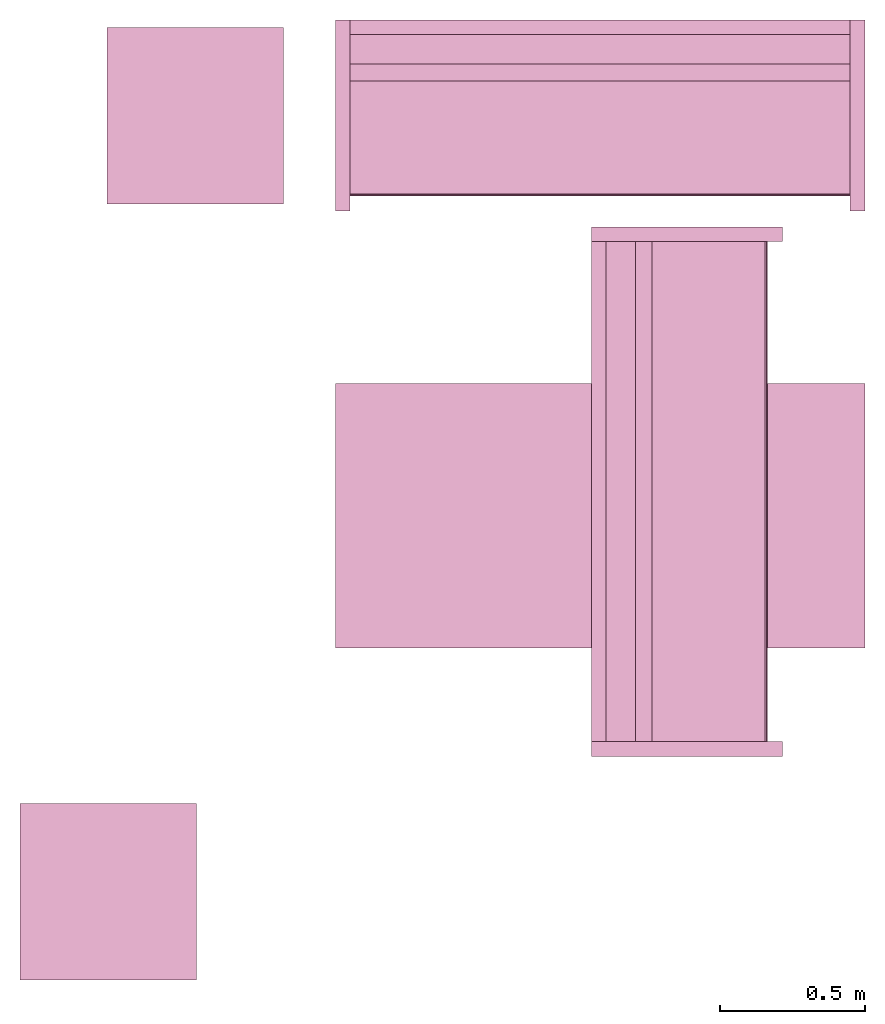
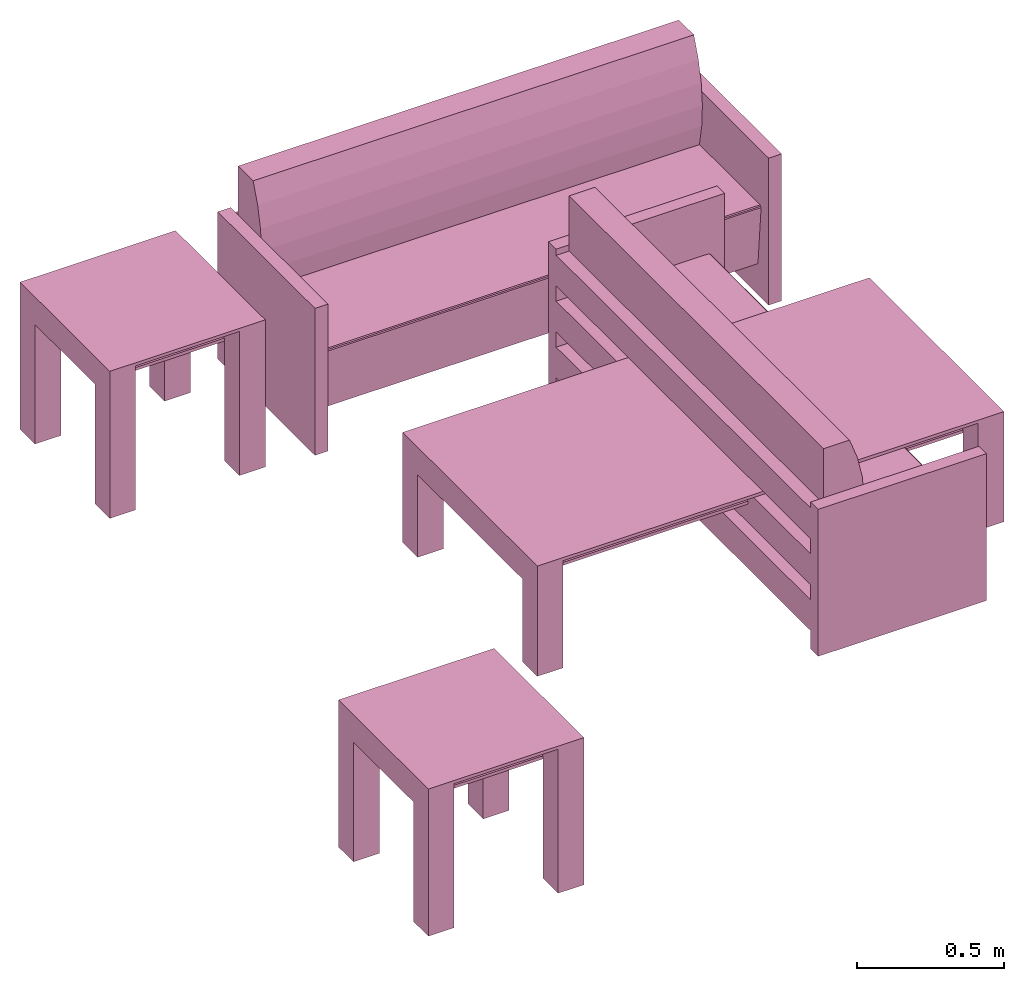
# One storey: 5 furnishings.
"""IFC2X3 building model written with IfcOpenShell, lengths in metres."""

from ifc_helpers import new_model, entity, si_unit, converted_unit, frame, origin, origin_with_axes, origin_2d_with_axis, place, context, project, spatial, polyline, rectangle, outline, extrude, face_set, surface_model, source, transform, mapped, type_object, type_shapes, element, save


model = new_model("IFC2X3")

# Units and contexts
model_context = context("Model", 3, precision=1e-09, world=origin())
plan_context = context("Plan", 3, precision=1e-09, world=origin())
ifc_project = project(units=[si_unit("LENGTHUNIT", "METRE"), si_unit("AREAUNIT", "SQUARE_METRE"), si_unit("VOLUMEUNIT", "CUBIC_METRE"), converted_unit("PLANEANGLEUNIT", "DEGREE", entity("IfcRatioMeasure", 0.0174532925199433), si_unit("PLANEANGLEUNIT", "RADIAN"), dimensions=[0, 0, 0, 0, 0, 0, 0]), si_unit("TIMEUNIT", "SECOND")], contexts=[model_context, plan_context])

# Site, building, storey, space
site_placement = place(None, origin_with_axes())
site = spatial("IfcSite", under=ifc_project, at=site_placement, CompositionType="ELEMENT")
building_placement = place(None, origin_with_axes())
building = spatial("IfcBuilding", under=site, at=building_placement, CompositionType="ELEMENT")
storey_placement = place(None, origin_with_axes())
storey = spatial("IfcBuildingStorey", under=building, at=storey_placement, Name="Level 1", CompositionType="ELEMENT", Elevation=0.0)
space_placement = place(None, origin_with_axes())
space = spatial("IfcSpace", under=storey, at=space_placement, CompositionType="ELEMENT", InteriorOrExteriorSpace="INTERNAL")

# Furnishings
furniture_type_1 = type_object("IfcFurnitureType", Name="0915 x 1830 x 0457mm", AssemblyPlace="NOTDEFINED")
shared_shape_1 = source(origin(), model_context, "Body", "SweptSolid", [
    extrude(rectangle(XDim=1.6268, YDim=0.711799999999999, at=origin_2d_with_axis()), frame((0.0182657666726317, 0.0952110778022268, 0.3427), z_axis=(0.0, 0.0, 1.0), x_axis=(-1.0, 0.0, 0.0)), (0.0, 0.0, 1.0), 0.0127),
    extrude(outline(polyline([(-0.196749999999994, -0.4575), (0.247549999999978, -0.4575), (0.247549999999978, 0.457499999999999), (-0.196749999999993, 0.457499999999999), (-0.196749999999993, 0.355900000000002), (0.145950000000009, 0.355900000000001), (0.145950000000009, -0.3559), (-0.196749999999994, -0.3559), (-0.196749999999994, -0.4575)])), frame((0.831665766672632, 0.0952110778022354, 0.196749999999991), z_axis=(1.0, 0.0, 0.0), x_axis=(0.0, 0.0, 1.0)), (0.0, 0.0, 1.0), 0.1016),
    extrude(outline(polyline([(-0.457500000000004, -0.247550000000026), (0.457499999999994, -0.247550000000026), (0.457499999999994, 0.196750000000011), (0.355900000000004, 0.196750000000011), (0.355900000000004, -0.145949999999996), (-0.355899999999994, -0.145949999999996), (-0.355899999999994, 0.196750000000011), (-0.457500000000004, 0.196750000000011), (-0.457500000000004, -0.247550000000026)])), frame((-0.896734233327367, 0.0952110778022256, 0.196750000000009), z_axis=(1.0, 0.0, 0.0), x_axis=(0.0, -1.0, 0.0)), (0.0, 0.0, 1.0), 0.1016),
    extrude(rectangle(XDim=1.6268, YDim=0.711799999999999, at=origin_2d_with_axis()), frame((0.0182657666726317, 0.0952110778022265, 0.4443), z_axis=(0.0, 0.0, 1.0), x_axis=(-1.0, 0.0, 0.0)), (0.0, 0.0, 1.0), 0.0127),
    extrude(outline(polyline([(-0.915, -0.457500000000023), (0.915, -0.457500000000023), (0.915, 0.457500000000023), (-0.915, 0.457500000000023), (-0.915, -0.457500000000023)]), holes=[polyline([(-0.813399999999998, -0.355899999999975), (-0.813399999999998, 0.355900000000025), (0.813400000000001, 0.355900000000024), (0.813400000000001, -0.355899999999975), (-0.813399999999998, -0.355899999999975)])]), frame((0.0182657666726332, 0.0952110778022514, 0.4443), z_axis=(0.0, 0.0, 1.0), x_axis=(-1.0, 0.0, 0.0)), (0.0, 0.0, 1.0), 0.0127),
])
type_shapes(furniture_type_1, [shared_shape_1])
furnishing_1_placement = place(None, frame((2.61916508073939, -15.3431715869351, 0.0), z_axis=(0.0, 0.0, 1.0), x_axis=(-1.0, 0.0, 0.0)))
element("IfcFurnishingElement", 1, at=furnishing_1_placement, inside=space, type_object=furniture_type_1, Name="M_Table-Coffee:0915 x 1830 x 0457mm:0915 x 1830 x 0457mm", context=model_context, shape_type="MappedRepresentation", body=[
    mapped(shared_shape_1, transform((0.0, 0.0, 0.0), scale=1.0)),
])
furniture_type_2 = type_object("IfcFurnitureType", Name="1830mm", AssemblyPlace="NOTDEFINED")
shared_shape_2 = source(origin(), model_context, "Body", "SurfaceModel", [
    surface_model("IfcFaceBasedSurfaceModel", [(0.0507999999999982, 0.609599999999997, 0.5842), (0.0507999999999983, 0.660399999999998, 0.5842), (0.0507999999999983, 0.660399999999998, 0.4572), (0.0507999999999982, 0.609599999999997, 0.4572), (0.0507999999999982, 0.609599999999998, 0.3937), (0.0507999999999983, 0.660399999999998, 0.3937), (0.0507999999999983, 0.660399999999998, 0.2667), (0.0507999999999982, 0.609599999999998, 0.2667), (0.0507999999999982, 0.609600000000004, 0.2032), (0.0507999999999983, 0.660399999999998, 0.2032), (0.0507999999999983, 0.660399999999998, 0.0762), (0.0507999999999982, 0.609600000000004, 0.0762), (1.77919999999999, 0.609599999999994, 0.5842), (1.77919999999999, 0.609599999999994, 0.4572), (1.77919999999999, 0.660399999999995, 0.4572), (1.77919999999999, 0.660399999999995, 0.5842), (1.77919999999999, 0.609599999999995, 0.3937), (1.77919999999999, 0.609599999999995, 0.2667), (1.77919999999999, 0.660399999999995, 0.2667), (1.77919999999999, 0.660399999999995, 0.3937), (1.77919999999999, 0.609600000000001, 0.2032), (1.77919999999999, 0.609600000000001, 0.0762), (1.77919999999999, 0.660399999999995, 0.0762), (1.77919999999999, 0.660399999999995, 0.2032), (0.0507999999999978, 0.470222395089521, 0.380999999999998), (0.0507999999999978, 0.454401348887885, 0.467831162756508), (0.0507999999999978, 0.450300415835913, 0.555996567971167), (0.0507999999999978, 0.457992845249543, 0.643921438504357), (0.0507999999999978, 0.477341237862486, 0.730035293556011), (0.0507999999999979, 0.507999999999975, 0.812799999999995), (0.0507999999999981, 0.609599999999998, 0.812799999999998), (0.0507999999999981, 0.609599999999998, 0.127966546684697), (0.0507999999999971, 0.0729375586579064, 0.127966546684697), (0.0507999999999971, 0.0520079452978146, 0.367193122067106), (0.0507999999999971, 0.0526336053189921, 0.372382281209352), (0.0507999999999971, 0.0552961957860913, 0.37687999563672), (0.0507999999999971, 0.0595447350023739, 0.379924455784818), (0.0507999999999971, 0.0646596179635799, 0.381000000000001), (1.77919999999998, 0.470222395089517, 0.381000000000001), (1.77919999999998, 0.0646596179635769, 0.381000000000001), (1.77919999999998, 0.059544735002371, 0.379924455784818), (1.77919999999998, 0.0552961957860883, 0.37687999563672), (1.77919999999998, 0.0526336053189891, 0.372382281209352), (1.77919999999998, 0.0520079452978117, 0.367193122067106), (1.77919999999998, 0.0729375586579034, 0.127966546684697), (1.77919999999998, 0.609599999999995, 0.127966546684697), (1.77919999999998, 0.609599999999995, 0.812799999999998), (1.77919999999998, 0.507999999999972, 0.812799999999995), (1.77919999999998, 0.477341237862483, 0.730035293556011), (1.77919999999998, 0.45799284524954, 0.643921438504357), (1.77919999999998, 0.45030041583591, 0.555996567971167), (1.77919999999998, 0.454401348887882, 0.467831162756508), (0.050799984484911, 0.0539648979902268, 0.374631136655807), (1.77919995784759, 0.0539648979902268, 0.374631136655807), (0.050799984484911, 0.0523207746446133, 0.369787722826004), (1.77919995784759, 0.0523207746446133, 0.369787722826004), (1.77919995784759, 0.0621021725237369, 0.380462229251862), (0.050799984484911, 0.0621788389980793, 0.380478352308273), (1.77919995784759, 0.0574204623699188, 0.378402233123779), (0.050799984484911, 0.0574204623699188, 0.378402233123779), (0.0507999999999971, 0.660399999999997, 0.6096), (0.0507999999999971, 0.0, 0.6096), (0.0, 0.0, 0.6096), (0.0, 0.660399999999997, 0.6096), (1.83, 0.660400000000039, 0.6096), (1.83, 0.0, 0.6096), (1.77919999999997, 0.0, 0.6096), (1.77919999999997, 0.660400000000039, 0.6096), (0.0507999999999971, 0.660399999999997, 0.0), (0.0507999999999971, 0.0, 0.0), (0.0, 0.0, 0.0), (0.0, 0.660399999999997, 0.0), (1.83, 0.660400000000039, 0.0), (1.83, 0.0, 0.0), (1.77919999999997, 0.0, 0.0), (1.77919999999997, 0.660400000000039, 0.0)], [face_set([[[0, 1, 2, 3]], [[4, 5, 6, 7]], [[8, 9, 10, 11]], [[12, 13, 14, 15]], [[16, 17, 18, 19]], [[20, 21, 22, 23]], [[1, 15, 12, 0]], [[2, 14, 15, 1]], [[3, 2, 14, 13]], [[0, 3, 13, 12]], [[5, 19, 16, 4]], [[6, 18, 19, 5]], [[7, 6, 18, 17]], [[4, 7, 17, 16]], [[9, 23, 20, 8]], [[10, 22, 23, 9]], [[11, 10, 22, 21]], [[8, 11, 21, 20]]]), face_set([[[24, 25, 26, 27, 28, 29, 30, 31, 32, 33, 34, 35, 36, 37]], [[38, 39, 40, 41, 42, 43, 44, 45, 46, 47, 48, 49, 50, 51]], [[24, 25, 51, 38]], [[25, 26, 50, 51]], [[49, 50, 26, 27]], [[27, 28, 48, 49]], [[28, 29, 47, 48]], [[30, 46, 47, 29]], [[31, 30, 46, 45]], [[32, 31, 45, 44]], [[33, 32, 44, 43]], [[41, 35, 52, 53]], [[54, 55, 42, 34]], [[33, 43, 55, 54]], [[34, 42, 53, 52]], [[39, 56, 57]], [[35, 41, 58, 59]], [[56, 40, 36]], [[57, 37, 39]], [[57, 56, 36]], [[40, 36, 59, 58]], [[24, 38, 39, 37]]]), face_set([[[60, 61, 62, 63]], [[64, 65, 66, 67]], [[68, 69, 70, 71]], [[72, 73, 74, 75]], [[63, 60, 68, 71]], [[62, 63, 71, 70]], [[61, 62, 70, 69]], [[60, 68, 69, 61]], [[67, 64, 72, 75]], [[66, 74, 75, 67]], [[65, 66, 74, 73]], [[64, 65, 73, 72]]])]),
])
type_shapes(furniture_type_2, [shared_shape_2])
furnishing_2_placement = place(None, frame((1.68589931406676, -14.3855826647373, 0.0), z_axis=(0.0, 0.0, 1.0), x_axis=(1.0, 0.0, 0.0)))
element("IfcFurnishingElement", 2, at=furnishing_2_placement, inside=space, type_object=furniture_type_2, Name="M_Sofa:1830mm:1830mm", context=model_context, shape_type="MappedRepresentation", body=[
    mapped(shared_shape_2, transform((0.0, 0.0, 0.0), scale=1.0)),
])
furnishing_3_placement = place(space_placement, frame((3.23109931406676, -16.2703826647373, 0.0), z_axis=(0.0, 0.0, 1.0), x_axis=(0.0, 1.0, 0.0)))
element("IfcFurnishingElement", 3, at=furnishing_3_placement, inside=space, type_object=furniture_type_2, Name="M_Sofa:1830mm:1830mm", context=model_context, shape_type="MappedRepresentation", body=[
    mapped(shared_shape_2, transform((0.0, 0.0, 0.0), scale=1.0)),
])
furniture_type_3 = type_object("IfcFurnitureType", Name="0610 x 0610 x 0610mm", AssemblyPlace="NOTDEFINED")
shared_shape_3 = source(origin(), model_context, "Body", "SweptSolid", [
    extrude(rectangle(XDim=0.406799999999999, YDim=0.406799999999999, at=origin_2d_with_axis()), frame((0.0182657666726316, 0.0952110778022263, 0.4957), z_axis=(0.0, 0.0, 1.0), x_axis=(-1.0, 0.0, 0.0)), (0.0, 0.0, 1.0), 0.0127),
    extrude(outline(polyline([(-0.273249999999994, -0.305), (0.324049999999978, -0.305), (0.324049999999978, 0.304999999999998), (-0.273249999999993, 0.304999999999999), (-0.273249999999993, 0.203400000000001), (0.222450000000009, 0.203400000000001), (0.222450000000009, -0.2034), (-0.273249999999994, -0.2034), (-0.273249999999994, -0.305)])), frame((0.221665766672633, 0.0952110778022354, 0.273249999999992), z_axis=(1.0, 0.0, 0.0), x_axis=(0.0, 0.0, 1.0)), (0.0, 0.0, 1.0), 0.1016),
    extrude(outline(polyline([(-0.305000000000004, -0.324050000000025), (0.304999999999994, -0.324050000000025), (0.304999999999994, 0.273250000000011), (0.203400000000004, 0.273250000000011), (0.203400000000004, -0.222449999999996), (-0.203399999999995, -0.222449999999996), (-0.203399999999995, 0.273250000000011), (-0.305000000000004, 0.273250000000011), (-0.305000000000004, -0.324050000000025)])), frame((-0.286734233327367, 0.0952110778022256, 0.273250000000008), z_axis=(1.0, 0.0, 0.0), x_axis=(0.0, -1.0, 0.0)), (0.0, 0.0, 1.0), 0.1016),
    extrude(rectangle(XDim=0.406799999999999, YDim=0.406799999999999, at=origin_2d_with_axis()), frame((0.0182657666726316, 0.0952110778022259, 0.5973), z_axis=(0.0, 0.0, 1.0), x_axis=(-1.0, 0.0, 0.0)), (0.0, 0.0, 1.0), 0.0127),
    extrude(outline(polyline([(-0.305, -0.305000000000023), (0.305, -0.305000000000023), (0.305, 0.305000000000023), (-0.305, 0.305000000000023), (-0.305, -0.305000000000023)]), holes=[polyline([(-0.203399999999998, -0.203399999999975), (-0.203399999999998, 0.203400000000025), (0.203400000000001, 0.203400000000025), (0.203400000000001, -0.203399999999975), (-0.203399999999998, -0.203399999999975)])]), frame((0.0182657666726332, 0.0952110778022508, 0.5973), z_axis=(0.0, 0.0, 1.0), x_axis=(-1.0, 0.0, 0.0)), (0.0, 0.0, 1.0), 0.0127),
])
type_shapes(furniture_type_3, [shared_shape_3])
for number, where, z_axis, x_axis, name in (
    (4, (1.21916508073938, -13.9601715869351, 0.0), (0.0, 0.0, 1.0), (-1.0, 0.0, 0.0), "M_Table-Coffee:0610 x 0610 x 0610mm:0610 x 0610 x 0610mm"),
    (5, (0.919165080739398, -16.6431715869351, 0.0), (0.0, 0.0, 1.0), (-1.0, 0.0, 0.0), "M_Table-Coffee:0610 x 0610 x 0610mm:0610 x 0610 x 0610mm"),
):
    element("IfcFurnishingElement", number, at=place(None, frame(where, z_axis=z_axis, x_axis=x_axis)), inside=space, type_object=furniture_type_3, Name=name, context=model_context, shape_type="MappedRepresentation", body=[
        mapped(shared_shape_3, transform((0.0, 0.0, 0.0), scale=1.0)),
    ])

save(model, "model.ifc")
